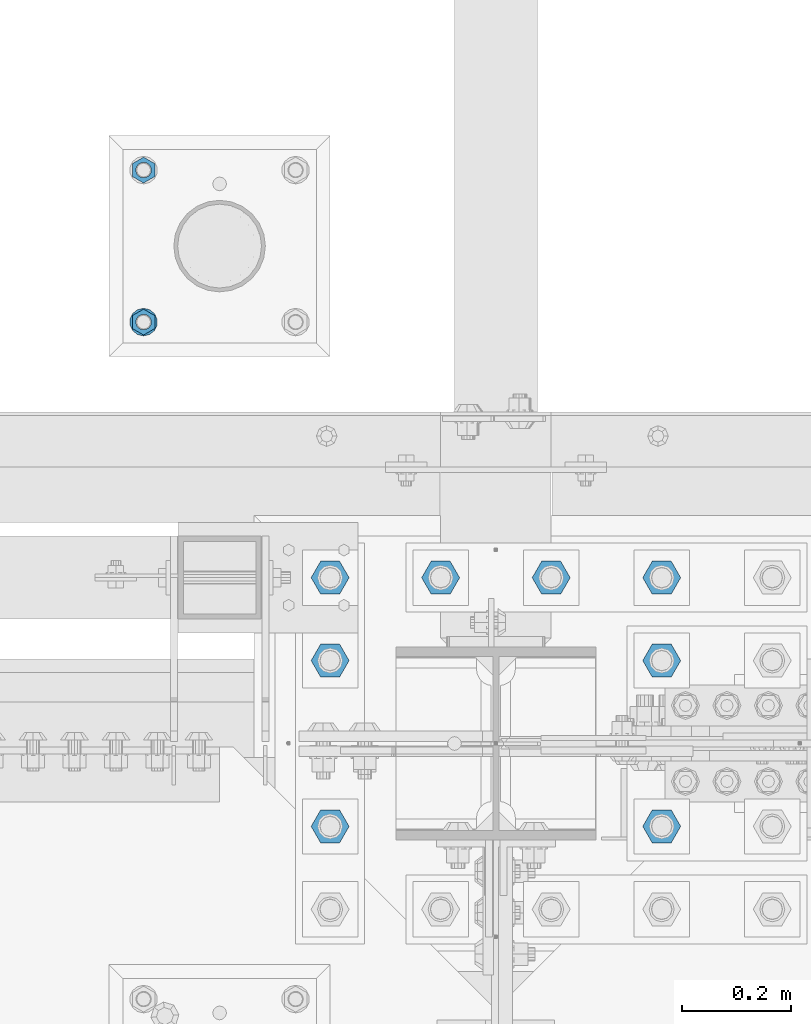
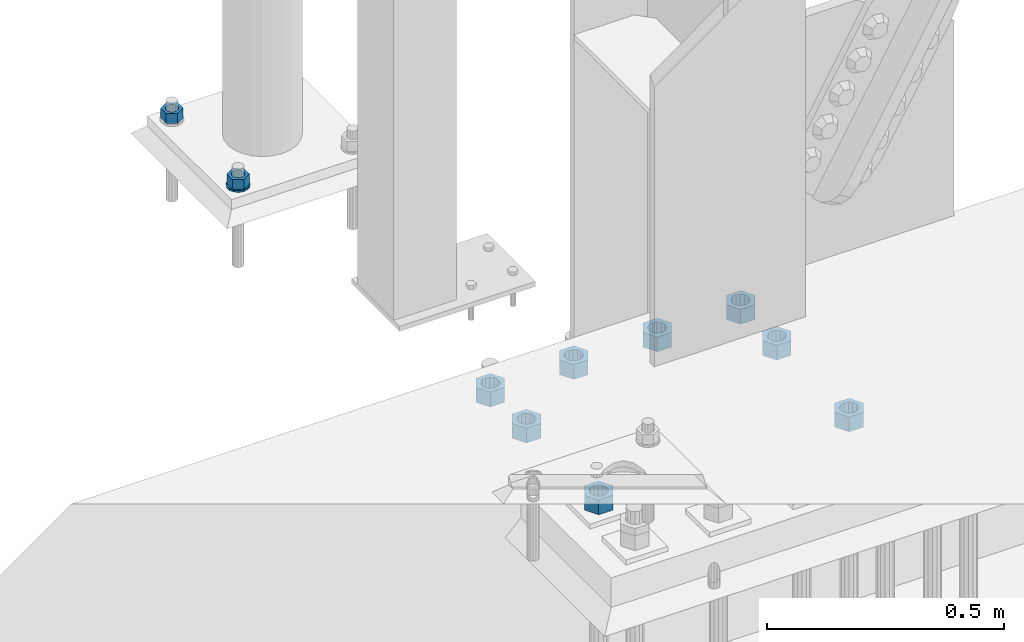
# One storey, part 1707 of 3843: 11 columns, 2 elements without a shape of their own.
"""IFC2X3 building model written with IfcOpenShell, lengths in millimetres."""

from ifc_helpers import new_model, si_unit, frame, origin_with_axes, place, context, subcontext, project, spatial, faceted_brep, material, type_object, element, aggregate, save


model = new_model("IFC2X3")

# Units and contexts
model_context = context("Model", 3, precision=1e-05, world=origin_with_axes())
body_context = subcontext(model_context, "Body", "Model", "MODEL_VIEW")
ifc_project = project(units=[si_unit("LENGTHUNIT", "METRE", prefix="MILLI"), si_unit("AREAUNIT", "SQUARE_METRE"), si_unit("VOLUMEUNIT", "CUBIC_METRE"), si_unit("MASSUNIT", "GRAM", prefix="KILO"), si_unit("TIMEUNIT", "SECOND"), si_unit("PLANEANGLEUNIT", "RADIAN"), si_unit("SOLIDANGLEUNIT", "STERADIAN"), si_unit("THERMODYNAMICTEMPERATUREUNIT", "DEGREE_CELSIUS"), si_unit("LUMINOUSINTENSITYUNIT", "LUMEN")], contexts=[model_context])

# Site, building, storey
site_placement = place(None, origin_with_axes())
site = spatial("IfcSite", under=ifc_project, at=site_placement, CompositionType="ELEMENT")
building_placement = place(site_placement, origin_with_axes())
building = spatial("IfcBuilding", under=site, at=building_placement, Name="Undefined", CompositionType="ELEMENT")
storey_placement = place(building_placement, origin_with_axes())
storey = spatial("IfcBuildingStorey", under=building, at=storey_placement, Name="Undefined", CompositionType="ELEMENT", Elevation=0.0)

# Assembly, columns
assembly_1_placement = place(storey_placement, origin_with_axes())
assembly_1 = element("IfcElementAssembly", 1, at=assembly_1_placement, inside=storey, Name="TEMPLATE", AssemblyPlace="NOTDEFINED", PredefinedType="RIGID_FRAME")
ifc_material = material(Name="STEEL/A572-50")
column_type_1 = type_object("IfcColumnType", Name="1_HEAVY_HEX_NUT", PredefinedType="NOTDEFINED")
column_1_placement = place(assembly_1_placement, frame((48348.9, 92989.4, 30560.9625), z_axis=(1.0, 0.0, 0.0), x_axis=(0.0, 0.0, -1.0)))
column_1 = element("IfcColumn", 2, at=column_1_placement, type_object=column_type_1, material=ifc_material, Name="NUT", ObjectType="1_HEAVY_HEX_NUT", context=body_context, shape_type="Brep", body=[
    faceted_brep([(0.0, -23.8099994659424, 0.0), (0.0, -11.9099998474121, -20.6200008392334), (25.3999999999978, -11.9099998474121, -20.6200008392334), (25.3999999999978, -23.8099994659424, 0.0), (0.0, 11.9099998474121, -20.6200008392334), (25.3999999999978, 11.9099998474121, -20.6200008392334), (0.0, 23.8099994659424, 0.0), (25.3999999999978, 23.8099994659424, 0.0), (0.0, 11.9099998474121, 20.6200008392334), (25.3999999999978, 11.9099998474121, 20.6200008392334), (0.0, -11.9099998474121, 20.6200008392334), (25.3999999999978, -11.9099998474121, 20.6200008392334), (0.0, 0.0, 14.289999961853), (0.0, 6.20019861543551, 12.8748450879575), (25.3999999999978, 6.20019861543551, 12.8748450879575), (25.3999999999978, 0.0, 14.289999961853), (0.0, 11.1723718546418, 8.90966924477834), (25.3999999999978, 11.1723718546418, 8.90966924477834), (0.0, 13.9317198278877, 3.17982413774735), (25.3999999999978, 13.9317198278877, 3.17982413774735), (0.0, 13.9317198278877, -3.17982413774735), (25.3999999999978, 13.9317198278877, -3.17982413774735), (0.0, 11.1723718546418, -8.90966924477834), (25.3999999999978, 11.1723718546418, -8.90966924477834), (0.0, 6.20019861543551, -12.8748450879575), (25.3999999999978, 6.20019861543551, -12.8748450879575), (0.0, 0.0, -14.289999961853), (25.3999999999978, 0.0, -14.289999961853), (0.0, -6.20019861543551, -12.8748450879575), (25.3999999999978, -6.20019861543551, -12.8748450879575), (0.0, -11.1723718546418, -8.90966924477834), (25.3999999999978, -11.1723718546418, -8.90966924477834), (0.0, -13.9317198278877, -3.17982413774735), (25.3999999999978, -13.9317198278877, -3.17982413774735), (0.0, -13.9317198278877, 3.17982413774735), (25.3999999999978, -13.9317198278877, 3.17982413774735), (0.0, -11.1723718546418, 8.90966924477834), (25.3999999999978, -11.1723718546418, 8.90966924477834), (0.0, -6.20019861543551, 12.8748450879575), (25.3999999999978, -6.20019861543551, 12.8748450879575)], [[[0, 1, 2, 3]], [[1, 4, 5, 2]], [[4, 6, 7, 5]], [[6, 8, 9, 7]], [[8, 10, 11, 9]], [[10, 0, 3, 11]], [[12, 13, 14, 15]], [[13, 16, 17, 14]], [[16, 18, 19, 17]], [[18, 20, 21, 19]], [[20, 22, 23, 21]], [[22, 24, 25, 23]], [[24, 26, 27, 25]], [[26, 28, 29, 27]], [[28, 30, 31, 29]], [[30, 32, 33, 31]], [[32, 34, 35, 33]], [[34, 36, 37, 35]], [[36, 38, 39, 37]], [[38, 12, 15, 39]], [[5, 7, 9, 11, 3, 2], [17, 19, 21, 23, 25, 27, 29, 31, 33, 35, 37, 39, 15, 14]], [[10, 8, 6, 4, 1, 0], [38, 36, 34, 32, 30, 28, 26, 24, 22, 20, 18, 16, 13, 12]]]),
])
column_2_placement = place(assembly_1_placement, frame((48348.9, 93268.8, 30560.9625), z_axis=(-1.0, 0.0, 0.0), x_axis=(0.0, 0.0, -1.0)))
column_2 = element("IfcColumn", 3, at=column_2_placement, type_object=column_type_1, material=ifc_material, Name="NUT", ObjectType="1_HEAVY_HEX_NUT", context=body_context, shape_type="Brep", body=[
    faceted_brep([(0.0, -23.8099994659424, 0.0), (0.0, -11.9099998474121, -20.6200008392334), (25.3999999999978, -11.9099998474121, -20.6200008392334), (25.3999999999978, -23.8099994659424, 0.0), (0.0, 11.9099998474121, -20.6200008392334), (25.3999999999978, 11.9099998474121, -20.6200008392334), (0.0, 23.8099994659424, 0.0), (25.3999999999978, 23.8099994659424, 0.0), (0.0, 11.9099998474121, 20.6200008392334), (25.3999999999978, 11.9099998474121, 20.6200008392334), (0.0, -11.9099998474121, 20.6200008392334), (25.3999999999978, -11.9099998474121, 20.6200008392334), (0.0, 0.0, 14.289999961853), (0.0, 6.20019861543551, 12.8748450879575), (25.3999999999978, 6.20019861543551, 12.8748450879575), (25.3999999999978, 0.0, 14.289999961853), (0.0, 11.1723718546418, 8.90966924477834), (25.3999999999978, 11.1723718546418, 8.90966924477834), (0.0, 13.9317198278877, 3.17982413774735), (25.3999999999978, 13.9317198278877, 3.17982413774735), (0.0, 13.9317198278877, -3.17982413774735), (25.3999999999978, 13.9317198278877, -3.17982413774735), (0.0, 11.1723718546418, -8.90966924477834), (25.3999999999978, 11.1723718546418, -8.90966924477834), (0.0, 6.20019861543551, -12.8748450879575), (25.3999999999978, 6.20019861543551, -12.8748450879575), (0.0, 0.0, -14.289999961853), (25.3999999999978, 0.0, -14.289999961853), (0.0, -6.20019861543551, -12.8748450879575), (25.3999999999978, -6.20019861543551, -12.8748450879575), (0.0, -11.1723718546418, -8.90966924477834), (25.3999999999978, -11.1723718546418, -8.90966924477834), (0.0, -13.9317198278877, -3.17982413774735), (25.3999999999978, -13.9317198278877, -3.17982413774735), (0.0, -13.9317198278877, 3.17982413774735), (25.3999999999978, -13.9317198278877, 3.17982413774735), (0.0, -11.1723718546418, 8.90966924477834), (25.3999999999978, -11.1723718546418, 8.90966924477834), (0.0, -6.20019861543551, 12.8748450879575), (25.3999999999978, -6.20019861543551, 12.8748450879575)], [[[0, 1, 2, 3]], [[1, 4, 5, 2]], [[4, 6, 7, 5]], [[6, 8, 9, 7]], [[8, 10, 11, 9]], [[10, 0, 3, 11]], [[12, 13, 14, 15]], [[13, 16, 17, 14]], [[16, 18, 19, 17]], [[18, 20, 21, 19]], [[20, 22, 23, 21]], [[22, 24, 25, 23]], [[24, 26, 27, 25]], [[26, 28, 29, 27]], [[28, 30, 31, 29]], [[30, 32, 33, 31]], [[32, 34, 35, 33]], [[34, 36, 37, 35]], [[36, 38, 39, 37]], [[38, 12, 15, 39]], [[5, 7, 9, 11, 3, 2], [17, 19, 21, 23, 25, 27, 29, 31, 33, 35, 37, 39, 15, 14]], [[10, 8, 6, 4, 1, 0], [38, 36, 34, 32, 30, 28, 26, 24, 22, 20, 18, 16, 13, 12]]]),
])
column_type_2 = type_object("IfcColumnType", Name="1_WASHER", PredefinedType="NOTDEFINED")
column_3_placement = place(assembly_1_placement, frame((48348.9, 92989.4, 30535.5625), z_axis=(1.0, 0.0, 0.0), x_axis=(0.0, 0.0, -1.0)))
column_3 = element("IfcColumn", 4, at=column_3_placement, type_object=column_type_2, material=ifc_material, Name="WASHER", ObjectType="1_WASHER", context=body_context, shape_type="Brep", body=[
    faceted_brep([(0.0, -25.3999996185303, 0.0), (0.0, -22.8846089010331, -11.0206468080723), (4.76250000000073, -22.8846089010331, -11.0206468080723), (4.76250000000073, -25.3999996185303, 0.0), (0.0, -15.8366407293652, -19.8585193564431), (4.76250000000073, -15.8366407293652, -19.8585193564431), (0.0, -5.6520316376118, -24.7631685975139), (4.76250000000073, -5.6520316376118, -24.7631685975139), (0.0, 5.6520316376118, -24.7631685975139), (4.76250000000073, 5.6520316376118, -24.7631685975139), (0.0, 15.8366407293652, -19.8585193564431), (4.76250000000073, 15.8366407293652, -19.8585193564431), (0.0, 22.8846089010331, -11.0206468080723), (4.76250000000073, 22.8846089010331, -11.0206468080723), (0.0, 25.3999996185303, 0.0), (4.76250000000073, 25.3999996185303, 0.0), (0.0, 22.8846089010331, 11.0206468080723), (4.76250000000073, 22.8846089010331, 11.0206468080723), (0.0, 15.8366407293652, 19.8585193564431), (4.76250000000073, 15.8366407293652, 19.8585193564431), (0.0, 5.6520316376118, 24.7631685975139), (4.76250000000073, 5.6520316376118, 24.7631685975139), (0.0, -5.6520316376118, 24.7631685975139), (4.76250000000073, -5.6520316376118, 24.7631685975139), (0.0, -15.8366407293652, 19.8585193564431), (4.76250000000073, -15.8366407293652, 19.8585193564431), (0.0, -22.8846089010331, 11.0206468080723), (4.76250000000073, -22.8846089010331, 11.0206468080723), (0.0, 0.0, 14.289999961853), (0.0, 6.20019861543551, 12.8748450879575), (4.76250000000073, 6.20019861543551, 12.8748450879575), (4.76250000000073, 0.0, 14.289999961853), (0.0, 11.1723718546418, 8.90966924477834), (4.76250000000073, 11.1723718546418, 8.90966924477834), (0.0, 13.9317198278877, 3.17982413774735), (4.76250000000073, 13.9317198278877, 3.17982413774735), (0.0, 13.9317198278877, -3.17982413774735), (4.76250000000073, 13.9317198278877, -3.17982413774735), (0.0, 11.1723718546418, -8.90966924477834), (4.76250000000073, 11.1723718546418, -8.90966924477834), (0.0, 6.20019861543551, -12.8748450879575), (4.76250000000073, 6.20019861543551, -12.8748450879575), (0.0, 0.0, -14.289999961853), (4.76250000000073, 0.0, -14.289999961853), (0.0, -6.20019861543551, -12.8748450879575), (4.76250000000073, -6.20019861543551, -12.8748450879575), (0.0, -11.1723718546418, -8.90966924477834), (4.76250000000073, -11.1723718546418, -8.90966924477834), (0.0, -13.9317198278877, -3.17982413774735), (4.76250000000073, -13.9317198278877, -3.17982413774735), (0.0, -13.9317198278877, 3.17982413774735), (4.76250000000073, -13.9317198278877, 3.17982413774735), (0.0, -11.1723718546418, 8.90966924477834), (4.76250000000073, -11.1723718546418, 8.90966924477834), (0.0, -6.20019861543551, 12.8748450879575), (4.76250000000073, -6.20019861543551, 12.8748450879575)], [[[0, 1, 2, 3]], [[1, 4, 5, 2]], [[4, 6, 7, 5]], [[6, 8, 9, 7]], [[8, 10, 11, 9]], [[10, 12, 13, 11]], [[12, 14, 15, 13]], [[14, 16, 17, 15]], [[16, 18, 19, 17]], [[18, 20, 21, 19]], [[20, 22, 23, 21]], [[22, 24, 25, 23]], [[24, 26, 27, 25]], [[26, 0, 3, 27]], [[28, 29, 30, 31]], [[29, 32, 33, 30]], [[32, 34, 35, 33]], [[34, 36, 37, 35]], [[36, 38, 39, 37]], [[38, 40, 41, 39]], [[40, 42, 43, 41]], [[42, 44, 45, 43]], [[44, 46, 47, 45]], [[46, 48, 49, 47]], [[48, 50, 51, 49]], [[50, 52, 53, 51]], [[52, 54, 55, 53]], [[54, 28, 31, 55]], [[5, 7, 9, 11, 13, 15, 17, 19, 21, 23, 25, 27, 3, 2], [33, 35, 37, 39, 41, 43, 45, 47, 49, 51, 53, 55, 31, 30]], [[26, 24, 22, 20, 18, 16, 14, 12, 10, 8, 6, 4, 1, 0], [54, 52, 50, 48, 46, 44, 42, 40, 38, 36, 34, 32, 29, 28]]]),
])
aggregate(assembly_1, [column_1, column_3, column_2])

assembly_2_placement = place(storey_placement, origin_with_axes())
assembly_2 = element("IfcElementAssembly", 5, at=assembly_2_placement, inside=storey, Name="TEMPLATE", AssemblyPlace="NOTDEFINED", PredefinedType="RIGID_FRAME")
column_type_3 = type_object("IfcColumnType", Name="1-1/2_HEAVY_HEX_NUT", PredefinedType="NOTDEFINED")
column_4_placement = place(assembly_2_placement, frame((48691.8, 92062.3, 30187.9), z_axis=(0.0, -1.0, 0.0), x_axis=(0.0, 0.0, -1.0)))
column_4 = element("IfcColumn", 6, at=column_4_placement, type_object=column_type_3, material=ifc_material, Name="NUT", ObjectType="1-1/2_HEAVY_HEX_NUT", context=body_context, shape_type="Brep", body=[
    faceted_brep([(0.0, -34.9199981689453, 0.0), (0.0, -17.4599990844727, -30.25), (38.0999999999985, -17.4599990844727, -30.25), (38.0999999999985, -34.9199981689453, 0.0), (0.0, 17.4599990844727, -30.25), (38.0999999999985, 17.4599990844727, -30.25), (0.0, 34.9199981689453, 0.0), (38.0999999999985, 34.9199981689453, 0.0), (0.0, 17.4599990844727, 30.25), (38.0999999999985, 17.4599990844727, 30.25), (0.0, -17.4599990844727, 30.25), (38.0999999999985, -17.4599990844727, 30.25), (0.0, 0.0, 20.6399993896484), (0.0, 8.9553601105581, 18.5959968835959), (38.0999999999985, 8.9553601105581, 18.5959968835959), (38.0999999999985, 0.0, 20.6399993896484), (0.0, 16.1370013209525, 12.8688291298167), (38.0999999999985, 16.1370013209525, 12.8688291298167), (0.0, 20.1225115123816, 4.59283194104501), (38.0999999999985, 20.1225115123816, 4.59283194104501), (0.0, 20.1225115123816, -4.59283194104501), (38.0999999999985, 20.1225115123816, -4.59283194104501), (0.0, 16.1370013209525, -12.8688291298167), (38.0999999999985, 16.1370013209525, -12.8688291298167), (0.0, 8.9553601105581, -18.5959968835959), (38.0999999999985, 8.9553601105581, -18.5959968835959), (0.0, 0.0, -20.6399993896484), (38.0999999999985, 0.0, -20.6399993896484), (0.0, -8.9553601105581, -18.5959968835959), (38.0999999999985, -8.9553601105581, -18.5959968835959), (0.0, -16.1370013209525, -12.8688291298167), (38.0999999999985, -16.1370013209525, -12.8688291298167), (0.0, -20.1225115123816, -4.59283194104501), (38.0999999999985, -20.1225115123816, -4.59283194104501), (0.0, -20.1225115123816, 4.59283194104501), (38.0999999999985, -20.1225115123816, 4.59283194104501), (0.0, -16.1370013209525, 12.8688291298167), (38.0999999999985, -16.1370013209525, 12.8688291298167), (0.0, -8.9553601105581, 18.5959968835959), (38.0999999999985, -8.9553601105581, 18.5959968835959)], [[[0, 1, 2, 3]], [[1, 4, 5, 2]], [[4, 6, 7, 5]], [[6, 8, 9, 7]], [[8, 10, 11, 9]], [[10, 0, 3, 11]], [[12, 13, 14, 15]], [[13, 16, 17, 14]], [[16, 18, 19, 17]], [[18, 20, 21, 19]], [[20, 22, 23, 21]], [[22, 24, 25, 23]], [[24, 26, 27, 25]], [[26, 28, 29, 27]], [[28, 30, 31, 29]], [[30, 32, 33, 31]], [[32, 34, 35, 33]], [[34, 36, 37, 35]], [[36, 38, 39, 37]], [[38, 12, 15, 39]], [[5, 7, 9, 11, 3, 2], [17, 19, 21, 23, 25, 27, 29, 31, 33, 35, 37, 39, 15, 14]], [[10, 8, 6, 4, 1, 0], [38, 36, 34, 32, 30, 28, 26, 24, 22, 20, 18, 16, 13, 12]]]),
])
column_5_placement = place(assembly_2_placement, frame((49301.4, 92062.3, 30187.9), z_axis=(0.0, 1.0, 0.0), x_axis=(0.0, 0.0, -1.0)))
column_5 = element("IfcColumn", 7, at=column_5_placement, type_object=column_type_3, material=ifc_material, Name="NUT", ObjectType="1-1/2_HEAVY_HEX_NUT", context=body_context, shape_type="Brep", body=[
    faceted_brep([(0.0, -34.9199981689453, 0.0), (0.0, -17.4599990844727, -30.25), (38.0999999999985, -17.4599990844727, -30.25), (38.0999999999985, -34.9199981689453, 0.0), (0.0, 17.4599990844727, -30.25), (38.0999999999985, 17.4599990844727, -30.25), (0.0, 34.9199981689453, 0.0), (38.0999999999985, 34.9199981689453, 0.0), (0.0, 17.4599990844727, 30.25), (38.0999999999985, 17.4599990844727, 30.25), (0.0, -17.4599990844727, 30.25), (38.0999999999985, -17.4599990844727, 30.25), (0.0, 0.0, 20.6399993896484), (0.0, 8.9553601105581, 18.5959968835959), (38.0999999999985, 8.9553601105581, 18.5959968835959), (38.0999999999985, 0.0, 20.6399993896484), (0.0, 16.1370013209525, 12.8688291298167), (38.0999999999985, 16.1370013209525, 12.8688291298167), (0.0, 20.1225115123816, 4.59283194104501), (38.0999999999985, 20.1225115123816, 4.59283194104501), (0.0, 20.1225115123816, -4.59283194104501), (38.0999999999985, 20.1225115123816, -4.59283194104501), (0.0, 16.1370013209525, -12.8688291298167), (38.0999999999985, 16.1370013209525, -12.8688291298167), (0.0, 8.9553601105581, -18.5959968835959), (38.0999999999985, 8.9553601105581, -18.5959968835959), (0.0, 0.0, -20.6399993896484), (38.0999999999985, 0.0, -20.6399993896484), (0.0, -8.9553601105581, -18.5959968835959), (38.0999999999985, -8.9553601105581, -18.5959968835959), (0.0, -16.1370013209525, -12.8688291298167), (38.0999999999985, -16.1370013209525, -12.8688291298167), (0.0, -20.1225115123816, -4.59283194104501), (38.0999999999985, -20.1225115123816, -4.59283194104501), (0.0, -20.1225115123816, 4.59283194104501), (38.0999999999985, -20.1225115123816, 4.59283194104501), (0.0, -16.1370013209525, 12.8688291298167), (38.0999999999985, -16.1370013209525, 12.8688291298167), (0.0, -8.9553601105581, 18.5959968835959), (38.0999999999985, -8.9553601105581, 18.5959968835959)], [[[0, 1, 2, 3]], [[1, 4, 5, 2]], [[4, 6, 7, 5]], [[6, 8, 9, 7]], [[8, 10, 11, 9]], [[10, 0, 3, 11]], [[12, 13, 14, 15]], [[13, 16, 17, 14]], [[16, 18, 19, 17]], [[18, 20, 21, 19]], [[20, 22, 23, 21]], [[22, 24, 25, 23]], [[24, 26, 27, 25]], [[26, 28, 29, 27]], [[28, 30, 31, 29]], [[30, 32, 33, 31]], [[32, 34, 35, 33]], [[34, 36, 37, 35]], [[36, 38, 39, 37]], [[38, 12, 15, 39]], [[5, 7, 9, 11, 3, 2], [17, 19, 21, 23, 25, 27, 29, 31, 33, 35, 37, 39, 15, 14]], [[10, 8, 6, 4, 1, 0], [38, 36, 34, 32, 30, 28, 26, 24, 22, 20, 18, 16, 13, 12]]]),
])
column_6_placement = place(assembly_2_placement, frame((48691.8, 92367.1, 30187.9), z_axis=(0.0, -1.0, 0.0), x_axis=(0.0, 0.0, -1.0)))
column_6 = element("IfcColumn", 8, at=column_6_placement, type_object=column_type_3, material=ifc_material, Name="NUT", ObjectType="1-1/2_HEAVY_HEX_NUT", context=body_context, shape_type="Brep", body=[
    faceted_brep([(0.0, -34.9199981689453, 0.0), (0.0, -17.4599990844727, -30.25), (38.0999999999985, -17.4599990844727, -30.25), (38.0999999999985, -34.9199981689453, 0.0), (0.0, 17.4599990844727, -30.25), (38.0999999999985, 17.4599990844727, -30.25), (0.0, 34.9199981689453, 0.0), (38.0999999999985, 34.9199981689453, 0.0), (0.0, 17.4599990844727, 30.25), (38.0999999999985, 17.4599990844727, 30.25), (0.0, -17.4599990844727, 30.25), (38.0999999999985, -17.4599990844727, 30.25), (0.0, 0.0, 20.6399993896484), (0.0, 8.9553601105581, 18.5959968835959), (38.0999999999985, 8.9553601105581, 18.5959968835959), (38.0999999999985, 0.0, 20.6399993896484), (0.0, 16.1370013209525, 12.8688291298167), (38.0999999999985, 16.1370013209525, 12.8688291298167), (0.0, 20.1225115123816, 4.59283194104501), (38.0999999999985, 20.1225115123816, 4.59283194104501), (0.0, 20.1225115123816, -4.59283194104501), (38.0999999999985, 20.1225115123816, -4.59283194104501), (0.0, 16.1370013209525, -12.8688291298167), (38.0999999999985, 16.1370013209525, -12.8688291298167), (0.0, 8.9553601105581, -18.5959968835959), (38.0999999999985, 8.9553601105581, -18.5959968835959), (0.0, 0.0, -20.6399993896484), (38.0999999999985, 0.0, -20.6399993896484), (0.0, -8.9553601105581, -18.5959968835959), (38.0999999999985, -8.9553601105581, -18.5959968835959), (0.0, -16.1370013209525, -12.8688291298167), (38.0999999999985, -16.1370013209525, -12.8688291298167), (0.0, -20.1225115123816, -4.59283194104501), (38.0999999999985, -20.1225115123816, -4.59283194104501), (0.0, -20.1225115123816, 4.59283194104501), (38.0999999999985, -20.1225115123816, 4.59283194104501), (0.0, -16.1370013209525, 12.8688291298167), (38.0999999999985, -16.1370013209525, 12.8688291298167), (0.0, -8.9553601105581, 18.5959968835959), (38.0999999999985, -8.9553601105581, 18.5959968835959)], [[[0, 1, 2, 3]], [[1, 4, 5, 2]], [[4, 6, 7, 5]], [[6, 8, 9, 7]], [[8, 10, 11, 9]], [[10, 0, 3, 11]], [[12, 13, 14, 15]], [[13, 16, 17, 14]], [[16, 18, 19, 17]], [[18, 20, 21, 19]], [[20, 22, 23, 21]], [[22, 24, 25, 23]], [[24, 26, 27, 25]], [[26, 28, 29, 27]], [[28, 30, 31, 29]], [[30, 32, 33, 31]], [[32, 34, 35, 33]], [[34, 36, 37, 35]], [[36, 38, 39, 37]], [[38, 12, 15, 39]], [[5, 7, 9, 11, 3, 2], [17, 19, 21, 23, 25, 27, 29, 31, 33, 35, 37, 39, 15, 14]], [[10, 8, 6, 4, 1, 0], [38, 36, 34, 32, 30, 28, 26, 24, 22, 20, 18, 16, 13, 12]]]),
])
column_7_placement = place(assembly_2_placement, frame((49301.4, 92367.1, 30187.9), z_axis=(0.0, 1.0, 0.0), x_axis=(0.0, 0.0, -1.0)))
column_7 = element("IfcColumn", 9, at=column_7_placement, type_object=column_type_3, material=ifc_material, Name="NUT", ObjectType="1-1/2_HEAVY_HEX_NUT", context=body_context, shape_type="Brep", body=[
    faceted_brep([(0.0, -34.9199981689453, 0.0), (0.0, -17.4599990844727, -30.25), (38.0999999999985, -17.4599990844727, -30.25), (38.0999999999985, -34.9199981689453, 0.0), (0.0, 17.4599990844727, -30.25), (38.0999999999985, 17.4599990844727, -30.25), (0.0, 34.9199981689453, 0.0), (38.0999999999985, 34.9199981689453, 0.0), (0.0, 17.4599990844727, 30.25), (38.0999999999985, 17.4599990844727, 30.25), (0.0, -17.4599990844727, 30.25), (38.0999999999985, -17.4599990844727, 30.25), (0.0, 0.0, 20.6399993896484), (0.0, 8.9553601105581, 18.5959968835959), (38.0999999999985, 8.9553601105581, 18.5959968835959), (38.0999999999985, 0.0, 20.6399993896484), (0.0, 16.1370013209525, 12.8688291298167), (38.0999999999985, 16.1370013209525, 12.8688291298167), (0.0, 20.1225115123816, 4.59283194104501), (38.0999999999985, 20.1225115123816, 4.59283194104501), (0.0, 20.1225115123816, -4.59283194104501), (38.0999999999985, 20.1225115123816, -4.59283194104501), (0.0, 16.1370013209525, -12.8688291298167), (38.0999999999985, 16.1370013209525, -12.8688291298167), (0.0, 8.9553601105581, -18.5959968835959), (38.0999999999985, 8.9553601105581, -18.5959968835959), (0.0, 0.0, -20.6399993896484), (38.0999999999985, 0.0, -20.6399993896484), (0.0, -8.9553601105581, -18.5959968835959), (38.0999999999985, -8.9553601105581, -18.5959968835959), (0.0, -16.1370013209525, -12.8688291298167), (38.0999999999985, -16.1370013209525, -12.8688291298167), (0.0, -20.1225115123816, -4.59283194104501), (38.0999999999985, -20.1225115123816, -4.59283194104501), (0.0, -20.1225115123816, 4.59283194104501), (38.0999999999985, -20.1225115123816, 4.59283194104501), (0.0, -16.1370013209525, 12.8688291298167), (38.0999999999985, -16.1370013209525, 12.8688291298167), (0.0, -8.9553601105581, 18.5959968835959), (38.0999999999985, -8.9553601105581, 18.5959968835959)], [[[0, 1, 2, 3]], [[1, 4, 5, 2]], [[4, 6, 7, 5]], [[6, 8, 9, 7]], [[8, 10, 11, 9]], [[10, 0, 3, 11]], [[12, 13, 14, 15]], [[13, 16, 17, 14]], [[16, 18, 19, 17]], [[18, 20, 21, 19]], [[20, 22, 23, 21]], [[22, 24, 25, 23]], [[24, 26, 27, 25]], [[26, 28, 29, 27]], [[28, 30, 31, 29]], [[30, 32, 33, 31]], [[32, 34, 35, 33]], [[34, 36, 37, 35]], [[36, 38, 39, 37]], [[38, 12, 15, 39]], [[5, 7, 9, 11, 3, 2], [17, 19, 21, 23, 25, 27, 29, 31, 33, 35, 37, 39, 15, 14]], [[10, 8, 6, 4, 1, 0], [38, 36, 34, 32, 30, 28, 26, 24, 22, 20, 18, 16, 13, 12]]]),
])
column_8_placement = place(assembly_2_placement, frame((48691.8, 92519.5, 30187.9), z_axis=(0.0, -1.0, 0.0), x_axis=(0.0, 0.0, -1.0)))
column_8 = element("IfcColumn", 10, at=column_8_placement, type_object=column_type_3, material=ifc_material, Name="NUT", ObjectType="1-1/2_HEAVY_HEX_NUT", context=body_context, shape_type="Brep", body=[
    faceted_brep([(0.0, -34.9199981689453, 0.0), (0.0, -17.4599990844727, -30.25), (38.0999999999985, -17.4599990844727, -30.25), (38.0999999999985, -34.9199981689453, 0.0), (0.0, 17.4599990844727, -30.25), (38.0999999999985, 17.4599990844727, -30.25), (0.0, 34.9199981689453, 0.0), (38.0999999999985, 34.9199981689453, 0.0), (0.0, 17.4599990844727, 30.25), (38.0999999999985, 17.4599990844727, 30.25), (0.0, -17.4599990844727, 30.25), (38.0999999999985, -17.4599990844727, 30.25), (0.0, 0.0, 20.6399993896484), (0.0, 8.9553601105581, 18.5959968835959), (38.0999999999985, 8.9553601105581, 18.5959968835959), (38.0999999999985, 0.0, 20.6399993896484), (0.0, 16.1370013209525, 12.8688291298167), (38.0999999999985, 16.1370013209525, 12.8688291298167), (0.0, 20.1225115123816, 4.59283194104501), (38.0999999999985, 20.1225115123816, 4.59283194104501), (0.0, 20.1225115123816, -4.59283194104501), (38.0999999999985, 20.1225115123816, -4.59283194104501), (0.0, 16.1370013209525, -12.8688291298167), (38.0999999999985, 16.1370013209525, -12.8688291298167), (0.0, 8.9553601105581, -18.5959968835959), (38.0999999999985, 8.9553601105581, -18.5959968835959), (0.0, 0.0, -20.6399993896484), (38.0999999999985, 0.0, -20.6399993896484), (0.0, -8.9553601105581, -18.5959968835959), (38.0999999999985, -8.9553601105581, -18.5959968835959), (0.0, -16.1370013209525, -12.8688291298167), (38.0999999999985, -16.1370013209525, -12.8688291298167), (0.0, -20.1225115123816, -4.59283194104501), (38.0999999999985, -20.1225115123816, -4.59283194104501), (0.0, -20.1225115123816, 4.59283194104501), (38.0999999999985, -20.1225115123816, 4.59283194104501), (0.0, -16.1370013209525, 12.8688291298167), (38.0999999999985, -16.1370013209525, 12.8688291298167), (0.0, -8.9553601105581, 18.5959968835959), (38.0999999999985, -8.9553601105581, 18.5959968835959)], [[[0, 1, 2, 3]], [[1, 4, 5, 2]], [[4, 6, 7, 5]], [[6, 8, 9, 7]], [[8, 10, 11, 9]], [[10, 0, 3, 11]], [[12, 13, 14, 15]], [[13, 16, 17, 14]], [[16, 18, 19, 17]], [[18, 20, 21, 19]], [[20, 22, 23, 21]], [[22, 24, 25, 23]], [[24, 26, 27, 25]], [[26, 28, 29, 27]], [[28, 30, 31, 29]], [[30, 32, 33, 31]], [[32, 34, 35, 33]], [[34, 36, 37, 35]], [[36, 38, 39, 37]], [[38, 12, 15, 39]], [[5, 7, 9, 11, 3, 2], [17, 19, 21, 23, 25, 27, 29, 31, 33, 35, 37, 39, 15, 14]], [[10, 8, 6, 4, 1, 0], [38, 36, 34, 32, 30, 28, 26, 24, 22, 20, 18, 16, 13, 12]]]),
])
column_9_placement = place(assembly_2_placement, frame((48895.0, 92519.5, 30187.9), z_axis=(0.0, -1.0, 0.0), x_axis=(0.0, 0.0, -1.0)))
column_9 = element("IfcColumn", 11, at=column_9_placement, type_object=column_type_3, material=ifc_material, Name="NUT", ObjectType="1-1/2_HEAVY_HEX_NUT", context=body_context, shape_type="Brep", body=[
    faceted_brep([(0.0, -34.9199981689453, 0.0), (0.0, -17.4599990844727, -30.25), (38.0999999999985, -17.4599990844727, -30.25), (38.0999999999985, -34.9199981689453, 0.0), (0.0, 17.4599990844727, -30.25), (38.0999999999985, 17.4599990844727, -30.25), (0.0, 34.9199981689453, 0.0), (38.0999999999985, 34.9199981689453, 0.0), (0.0, 17.4599990844727, 30.25), (38.0999999999985, 17.4599990844727, 30.25), (0.0, -17.4599990844727, 30.25), (38.0999999999985, -17.4599990844727, 30.25), (0.0, 0.0, 20.6399993896484), (0.0, 8.9553601105581, 18.5959968835959), (38.0999999999985, 8.9553601105581, 18.5959968835959), (38.0999999999985, 0.0, 20.6399993896484), (0.0, 16.1370013209525, 12.8688291298167), (38.0999999999985, 16.1370013209525, 12.8688291298167), (0.0, 20.1225115123816, 4.59283194104501), (38.0999999999985, 20.1225115123816, 4.59283194104501), (0.0, 20.1225115123816, -4.59283194104501), (38.0999999999985, 20.1225115123816, -4.59283194104501), (0.0, 16.1370013209525, -12.8688291298167), (38.0999999999985, 16.1370013209525, -12.8688291298167), (0.0, 8.9553601105581, -18.5959968835959), (38.0999999999985, 8.9553601105581, -18.5959968835959), (0.0, 0.0, -20.6399993896484), (38.0999999999985, 0.0, -20.6399993896484), (0.0, -8.9553601105581, -18.5959968835959), (38.0999999999985, -8.9553601105581, -18.5959968835959), (0.0, -16.1370013209525, -12.8688291298167), (38.0999999999985, -16.1370013209525, -12.8688291298167), (0.0, -20.1225115123816, -4.59283194104501), (38.0999999999985, -20.1225115123816, -4.59283194104501), (0.0, -20.1225115123816, 4.59283194104501), (38.0999999999985, -20.1225115123816, 4.59283194104501), (0.0, -16.1370013209525, 12.8688291298167), (38.0999999999985, -16.1370013209525, 12.8688291298167), (0.0, -8.9553601105581, 18.5959968835959), (38.0999999999985, -8.9553601105581, 18.5959968835959)], [[[0, 1, 2, 3]], [[1, 4, 5, 2]], [[4, 6, 7, 5]], [[6, 8, 9, 7]], [[8, 10, 11, 9]], [[10, 0, 3, 11]], [[12, 13, 14, 15]], [[13, 16, 17, 14]], [[16, 18, 19, 17]], [[18, 20, 21, 19]], [[20, 22, 23, 21]], [[22, 24, 25, 23]], [[24, 26, 27, 25]], [[26, 28, 29, 27]], [[28, 30, 31, 29]], [[30, 32, 33, 31]], [[32, 34, 35, 33]], [[34, 36, 37, 35]], [[36, 38, 39, 37]], [[38, 12, 15, 39]], [[5, 7, 9, 11, 3, 2], [17, 19, 21, 23, 25, 27, 29, 31, 33, 35, 37, 39, 15, 14]], [[10, 8, 6, 4, 1, 0], [38, 36, 34, 32, 30, 28, 26, 24, 22, 20, 18, 16, 13, 12]]]),
])
column_10_placement = place(assembly_2_placement, frame((49098.2, 92519.5, 30187.9), z_axis=(0.0, -1.0, 0.0), x_axis=(0.0, 0.0, -1.0)))
column_10 = element("IfcColumn", 12, at=column_10_placement, type_object=column_type_3, material=ifc_material, Name="NUT", ObjectType="1-1/2_HEAVY_HEX_NUT", context=body_context, shape_type="Brep", body=[
    faceted_brep([(0.0, -34.9199981689453, 0.0), (0.0, -17.4599990844727, -30.25), (38.0999999999985, -17.4599990844727, -30.25), (38.0999999999985, -34.9199981689453, 0.0), (0.0, 17.4599990844727, -30.25), (38.0999999999985, 17.4599990844727, -30.25), (0.0, 34.9199981689453, 0.0), (38.0999999999985, 34.9199981689453, 0.0), (0.0, 17.4599990844727, 30.25), (38.0999999999985, 17.4599990844727, 30.25), (0.0, -17.4599990844727, 30.25), (38.0999999999985, -17.4599990844727, 30.25), (0.0, 0.0, 20.6399993896484), (0.0, 8.9553601105581, 18.5959968835959), (38.0999999999985, 8.9553601105581, 18.5959968835959), (38.0999999999985, 0.0, 20.6399993896484), (0.0, 16.1370013209525, 12.8688291298167), (38.0999999999985, 16.1370013209525, 12.8688291298167), (0.0, 20.1225115123816, 4.59283194104501), (38.0999999999985, 20.1225115123816, 4.59283194104501), (0.0, 20.1225115123816, -4.59283194104501), (38.0999999999985, 20.1225115123816, -4.59283194104501), (0.0, 16.1370013209525, -12.8688291298167), (38.0999999999985, 16.1370013209525, -12.8688291298167), (0.0, 8.9553601105581, -18.5959968835959), (38.0999999999985, 8.9553601105581, -18.5959968835959), (0.0, 0.0, -20.6399993896484), (38.0999999999985, 0.0, -20.6399993896484), (0.0, -8.9553601105581, -18.5959968835959), (38.0999999999985, -8.9553601105581, -18.5959968835959), (0.0, -16.1370013209525, -12.8688291298167), (38.0999999999985, -16.1370013209525, -12.8688291298167), (0.0, -20.1225115123816, -4.59283194104501), (38.0999999999985, -20.1225115123816, -4.59283194104501), (0.0, -20.1225115123816, 4.59283194104501), (38.0999999999985, -20.1225115123816, 4.59283194104501), (0.0, -16.1370013209525, 12.8688291298167), (38.0999999999985, -16.1370013209525, 12.8688291298167), (0.0, -8.9553601105581, 18.5959968835959), (38.0999999999985, -8.9553601105581, 18.5959968835959)], [[[0, 1, 2, 3]], [[1, 4, 5, 2]], [[4, 6, 7, 5]], [[6, 8, 9, 7]], [[8, 10, 11, 9]], [[10, 0, 3, 11]], [[12, 13, 14, 15]], [[13, 16, 17, 14]], [[16, 18, 19, 17]], [[18, 20, 21, 19]], [[20, 22, 23, 21]], [[22, 24, 25, 23]], [[24, 26, 27, 25]], [[26, 28, 29, 27]], [[28, 30, 31, 29]], [[30, 32, 33, 31]], [[32, 34, 35, 33]], [[34, 36, 37, 35]], [[36, 38, 39, 37]], [[38, 12, 15, 39]], [[5, 7, 9, 11, 3, 2], [17, 19, 21, 23, 25, 27, 29, 31, 33, 35, 37, 39, 15, 14]], [[10, 8, 6, 4, 1, 0], [38, 36, 34, 32, 30, 28, 26, 24, 22, 20, 18, 16, 13, 12]]]),
])
column_11_placement = place(assembly_2_placement, frame((49301.4, 92519.5, 30187.9), z_axis=(0.0, 1.0, 0.0), x_axis=(0.0, 0.0, -1.0)))
column_11 = element("IfcColumn", 13, at=column_11_placement, type_object=column_type_3, material=ifc_material, Name="NUT", ObjectType="1-1/2_HEAVY_HEX_NUT", context=body_context, shape_type="Brep", body=[
    faceted_brep([(0.0, -34.9199981689453, 0.0), (0.0, -17.4599990844727, -30.25), (38.0999999999985, -17.4599990844727, -30.25), (38.0999999999985, -34.9199981689453, 0.0), (0.0, 17.4599990844727, -30.25), (38.0999999999985, 17.4599990844727, -30.25), (0.0, 34.9199981689453, 0.0), (38.0999999999985, 34.9199981689453, 0.0), (0.0, 17.4599990844727, 30.25), (38.0999999999985, 17.4599990844727, 30.25), (0.0, -17.4599990844727, 30.25), (38.0999999999985, -17.4599990844727, 30.25), (0.0, 0.0, 20.6399993896484), (0.0, 8.9553601105581, 18.5959968835959), (38.0999999999985, 8.9553601105581, 18.5959968835959), (38.0999999999985, 0.0, 20.6399993896484), (0.0, 16.1370013209525, 12.8688291298167), (38.0999999999985, 16.1370013209525, 12.8688291298167), (0.0, 20.1225115123816, 4.59283194104501), (38.0999999999985, 20.1225115123816, 4.59283194104501), (0.0, 20.1225115123816, -4.59283194104501), (38.0999999999985, 20.1225115123816, -4.59283194104501), (0.0, 16.1370013209525, -12.8688291298167), (38.0999999999985, 16.1370013209525, -12.8688291298167), (0.0, 8.9553601105581, -18.5959968835959), (38.0999999999985, 8.9553601105581, -18.5959968835959), (0.0, 0.0, -20.6399993896484), (38.0999999999985, 0.0, -20.6399993896484), (0.0, -8.9553601105581, -18.5959968835959), (38.0999999999985, -8.9553601105581, -18.5959968835959), (0.0, -16.1370013209525, -12.8688291298167), (38.0999999999985, -16.1370013209525, -12.8688291298167), (0.0, -20.1225115123816, -4.59283194104501), (38.0999999999985, -20.1225115123816, -4.59283194104501), (0.0, -20.1225115123816, 4.59283194104501), (38.0999999999985, -20.1225115123816, 4.59283194104501), (0.0, -16.1370013209525, 12.8688291298167), (38.0999999999985, -16.1370013209525, 12.8688291298167), (0.0, -8.9553601105581, 18.5959968835959), (38.0999999999985, -8.9553601105581, 18.5959968835959)], [[[0, 1, 2, 3]], [[1, 4, 5, 2]], [[4, 6, 7, 5]], [[6, 8, 9, 7]], [[8, 10, 11, 9]], [[10, 0, 3, 11]], [[12, 13, 14, 15]], [[13, 16, 17, 14]], [[16, 18, 19, 17]], [[18, 20, 21, 19]], [[20, 22, 23, 21]], [[22, 24, 25, 23]], [[24, 26, 27, 25]], [[26, 28, 29, 27]], [[28, 30, 31, 29]], [[30, 32, 33, 31]], [[32, 34, 35, 33]], [[34, 36, 37, 35]], [[36, 38, 39, 37]], [[38, 12, 15, 39]], [[5, 7, 9, 11, 3, 2], [17, 19, 21, 23, 25, 27, 29, 31, 33, 35, 37, 39, 15, 14]], [[10, 8, 6, 4, 1, 0], [38, 36, 34, 32, 30, 28, 26, 24, 22, 20, 18, 16, 13, 12]]]),
])
aggregate(assembly_2, [column_4, column_5, column_6, column_7, column_8, column_9, column_10, column_11])

save(model, "model.ifc")
